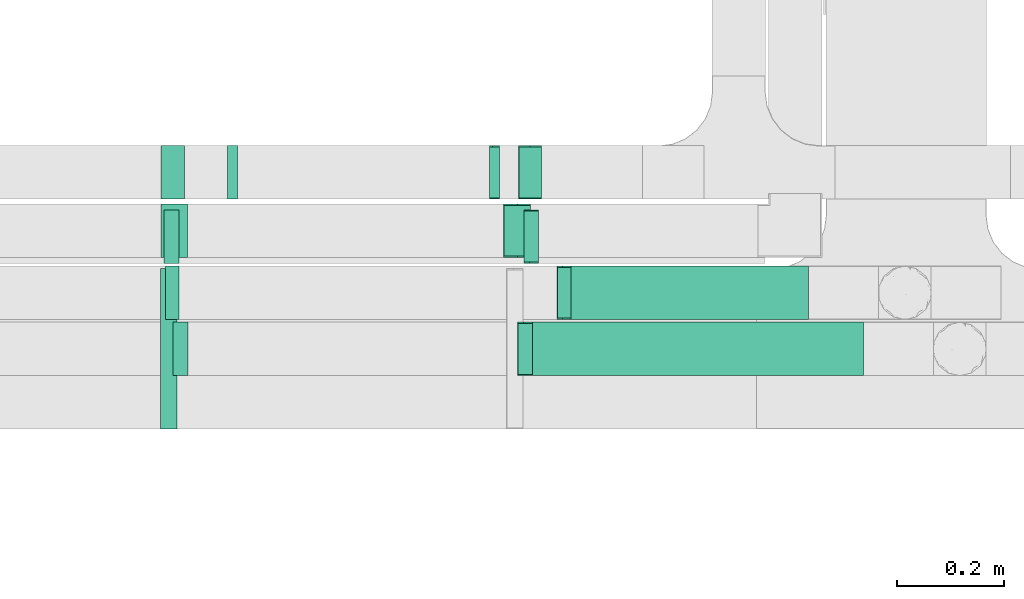
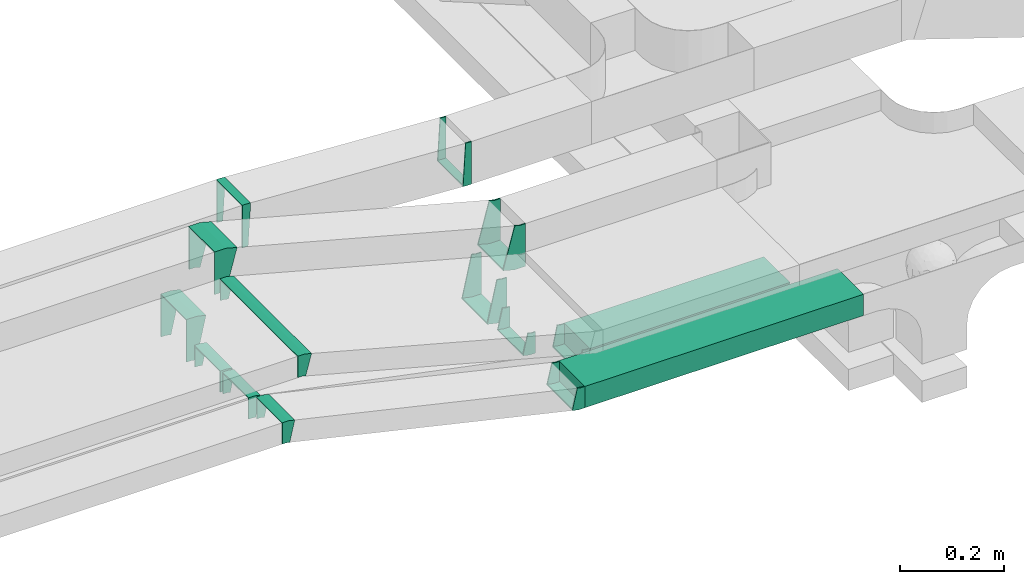
# One storey, part 13 of 18: 13 flow fittings, 2 flow segments.
"""IFC2X3 building model written with IfcOpenShell, lengths in millimetres."""

from ifc_helpers import new_model, entity, si_unit, converted_unit, derived_unit, direction, frame, frame_2d, origin, origin_2d_with_axis, place, context, subcontext, project, spatial, rectangle, extrude, faceted_brep, source, transform, mapped, material, type_object, type_shapes, element, save


model = new_model("IFC2X3")

# Units and contexts
model_context = context("Model", 3, precision=0.01, world=origin(), true_north=direction((6.12303176911189e-17, 1.0)))
body_context = subcontext(model_context, "Body", "Model", "MODEL_VIEW")
ifc_project = project(units=[si_unit("LENGTHUNIT", "METRE", prefix="MILLI"), si_unit("AREAUNIT", "SQUARE_METRE"), si_unit("VOLUMEUNIT", "CUBIC_METRE"), converted_unit("PLANEANGLEUNIT", "DEGREE", entity("IfcRatioMeasure", 0.0174532925199433), si_unit("PLANEANGLEUNIT", "RADIAN"), dimensions=[0, 0, 0, 0, 0, 0, 0]), si_unit("MASSUNIT", "GRAM", prefix="KILO"), derived_unit("MASSDENSITYUNIT", [(si_unit("MASSUNIT", "GRAM", prefix="KILO"), 1), (si_unit("LENGTHUNIT", "METRE"), -3)]), derived_unit("MOMENTOFINERTIAUNIT", [(si_unit("LENGTHUNIT", "METRE"), 4)]), si_unit("TIMEUNIT", "SECOND"), si_unit("FREQUENCYUNIT", "HERTZ"), si_unit("THERMODYNAMICTEMPERATUREUNIT", "DEGREE_CELSIUS"), derived_unit("THERMALTRANSMITTANCEUNIT", [(si_unit("MASSUNIT", "GRAM", prefix="KILO"), 1), (si_unit("THERMODYNAMICTEMPERATUREUNIT", "KELVIN"), -1), (si_unit("TIMEUNIT", "SECOND"), -3)]), derived_unit("VOLUMETRICFLOWRATEUNIT", [(si_unit("LENGTHUNIT", "METRE"), 3), (si_unit("TIMEUNIT", "SECOND"), -1)]), derived_unit("MASSFLOWRATEUNIT", [(si_unit("MASSUNIT", "GRAM", prefix="KILO"), 1), (si_unit("TIMEUNIT", "SECOND"), -1)]), derived_unit("ROTATIONALFREQUENCYUNIT", [(si_unit("TIMEUNIT", "SECOND"), -1)]), si_unit("ELECTRICCURRENTUNIT", "AMPERE"), si_unit("ELECTRICVOLTAGEUNIT", "VOLT"), si_unit("POWERUNIT", "WATT"), si_unit("FORCEUNIT", "NEWTON", prefix="KILO"), si_unit("ILLUMINANCEUNIT", "LUX"), si_unit("LUMINOUSFLUXUNIT", "LUMEN"), si_unit("LUMINOUSINTENSITYUNIT", "CANDELA"), derived_unit("USERDEFINED", [(si_unit("MASSUNIT", "GRAM", prefix="KILO"), -1), (si_unit("LENGTHUNIT", "METRE"), -2), (si_unit("TIMEUNIT", "SECOND"), 3), (si_unit("LUMINOUSFLUXUNIT", "LUMEN"), 1)]), derived_unit("LINEARVELOCITYUNIT", [(si_unit("LENGTHUNIT", "METRE"), 1), (si_unit("TIMEUNIT", "SECOND"), -1)]), si_unit("PRESSUREUNIT", "PASCAL"), derived_unit("USERDEFINED", [(si_unit("LENGTHUNIT", "METRE"), -2), (si_unit("MASSUNIT", "GRAM", prefix="KILO"), 1), (si_unit("TIMEUNIT", "SECOND"), -2)]), derived_unit("LINEARFORCEUNIT", [(si_unit("MASSUNIT", "GRAM", prefix="KILO"), 1), (si_unit("LENGTHUNIT", "METRE"), 1), (si_unit("TIMEUNIT", "SECOND"), -2), (si_unit("LENGTHUNIT", "METRE"), -1)]), derived_unit("PLANARFORCEUNIT", [(si_unit("MASSUNIT", "GRAM", prefix="KILO"), 1), (si_unit("LENGTHUNIT", "METRE"), 1), (si_unit("TIMEUNIT", "SECOND"), -2), (si_unit("LENGTHUNIT", "METRE"), -2)])], contexts=[model_context])

# Site, building, storey
site_placement = place(None, frame((0.0, -0.00077364408347762, 0.0)))
site = spatial("IfcSite", under=ifc_project, at=site_placement, CompositionType="ELEMENT")
building_placement = place(site_placement, origin())
building = spatial("IfcBuilding", under=site, at=building_placement, CompositionType="ELEMENT")
storey_placement = place(building_placement, frame((0.0, 0.0, 19800.0)))
storey = spatial("IfcBuildingStorey", under=building, at=storey_placement, CompositionType="ELEMENT", Elevation=19800.0)

# Flow segments
cable_carrier_segment_type = type_object("IfcCableCarrierSegmentType", PredefinedType="CABLETRAYSEGMENT")
flow_segment_1_placement = place(storey_placement, frame((63916.0659543254, 9720.00008284602, 2800.0)))
element("IfcFlowSegment", 1, at=flow_segment_1_placement, inside=storey, type_object=cable_carrier_segment_type, context=body_context, shape_type="SweptSolid", body=[
    extrude(rectangle(XDim=444.461560115162, YDim=99.9999999999989, at=origin_2d_with_axis()), frame((222.230780057581, 50.0, 0.0), z_axis=(0.0, 0.0, 1.0), x_axis=(-1.0, 0.0, 0.0)), (0.0, 0.0, 1.0), 49.9999999999973),
])
flow_segment_2_placement = place(storey_placement, frame((63844.3615033926, 9615.00008284603, 2800.0)))
element("IfcFlowSegment", 2, at=flow_segment_2_placement, inside=storey, type_object=cable_carrier_segment_type, context=body_context, shape_type="SweptSolid", body=[
    extrude(rectangle(XDim=618.676195552314, YDim=100.000000000001, at=frame_2d((4.34852154285181e-12, -5.43565192856477e-13), x_axis=(1.0, 0.0))), frame((309.338097776153, 50.0, 0.0), z_axis=(0.0, 0.0, 1.0), x_axis=(-1.0, 0.0, 0.0)), (0.0, 0.0, 1.0), 49.9999999999973),
])

# Flow fittings
ifc_material = material()
cable_carrier_fitting_type_1 = type_object("IfcCableCarrierFittingType", PredefinedType="NOTDEFINED", material=ifc_material)
shared_shape_1 = source(origin(), body_context, "Body", "Brep", [
    faceted_brep([(-12.240887367307, -25.0, 150.0), (-12.2408873673069, 25.0, 150.0), (-12.2408873673069, 25.0, 147.460000010164), (-12.240887367307, -22.46000001016, 147.460000010164), (-12.240887367307, -22.46000001016, -147.460000010156), (-12.2408873673069, 25.0, -147.460000010156), (-12.2408873673069, 25.0, -150.0), (-12.240887367307, -25.0, -150.0), (18.2942653723417, -20.9799708776128, 150.0), (18.2942653723417, -20.9799708776128, -150.0), (5.35331311721466, 27.3163204368403, -150.0), (5.35331311721466, 27.3163204368404, -147.460000010156), (17.6368650004108, -18.5265192886524, -147.460000010156), (17.6368650004108, -18.5265192886524, 147.460000010164), (5.35331311721466, 27.3163204368403, 147.460000010164), (5.35331311721466, 27.3163204368403, 150.0), (3.29131243968552, -25.0, 150.0), (-3.29131243968474, 25.0, 150.0), (-3.29131243968474, 25.0, 147.460000010164), (2.95691509715105, -22.46000001016, 147.460000010164), (2.95691509715105, -22.46000001016, -147.460000010156), (-3.29131243968474, 25.0, -147.460000010156), (-3.29131243968474, 25.0, -150.0), (3.29131243968546, -25.0, -150.0)], [[[0, 1, 2, 3, 4, 5, 6, 7]], [[8, 9, 10, 11, 12, 13, 14, 15]], [[1, 0, 16, 8, 15, 17]], [[2, 1, 17, 18]], [[3, 2, 18, 14, 13, 19]], [[4, 3, 19, 20]], [[5, 4, 20, 12, 11, 21]], [[6, 5, 21, 22]], [[7, 6, 22, 10, 9, 23]], [[0, 7, 23, 16]], [[18, 17, 15, 14]], [[20, 19, 13, 12]], [[22, 21, 11, 10]], [[16, 23, 9, 8]]]),
])
type_shapes(cable_carrier_fitting_type_1, [shared_shape_1])
flow_fitting_placement = place(storey_placement, frame((63161.1898333091, 9665.00005445351, 3200.0), z_axis=(0.0, -1.0, -1.62242998689715e-07), x_axis=(-0.965925826289063, -4.19915779954446e-08, 0.258819045102537)))
element("IfcFlowFitting", 3, at=flow_fitting_placement, inside=storey, type_object=cable_carrier_fitting_type_1, material=ifc_material, context=body_context, shape_type="MappedRepresentation", body=[
    mapped(shared_shape_1, transform((0.0, 0.0, 0.0), scale=1.0)),
])
cable_carrier_fitting_type_2 = type_object("IfcCableCarrierFittingType", PredefinedType="NOTDEFINED", material=ifc_material)
shared_shape_2 = source(origin(), body_context, "Body", "Brep", [
    faceted_brep([(-8.01131647543976, -50.0, 50.0), (-8.01131647543943, 50.0, 50.0), (-8.01131647543943, 50.0, 47.4600000101635), (-8.01131647543975, -47.46000001016, 47.4600000101635), (-8.01131647543975, -47.46000001016, -47.4600000101565), (-8.01131647543943, 50.0, -47.4600000101565), (-8.01131647543943, 50.0, -50.0), (-8.01131647543976, -50.0, -50.0), (10.8637122780125, -49.4586791899083, 50.0), (10.8637122780125, -49.4586791899083, -50.0), (5.13258520593124, 50.3769566446155, -50.0), (5.13258520593124, 50.3769566446155, -47.4600000101565), (10.7181416509639, -46.9228540498547, -47.4600000101565), (10.7181416509639, -46.9228540498547, 47.4600000101635), (5.13258520593124, 50.3769566446155, 47.4600000101635), (5.13258520593124, 50.3769566446155, 50.0), (1.43396022640025, -50.0, 50.0), (-1.43396022639952, 50.0, 50.0), (-1.43396022639952, 50.0, 47.4600000101635), (1.3611150471905, -47.46000001016, 47.4600000101635), (1.3611150471905, -47.46000001016, -47.4600000101565), (-1.43396022639952, 50.0, -47.4600000101565), (-1.43396022639952, 50.0, -50.0), (1.43396022640023, -50.0, -50.0)], [[[0, 1, 2, 3, 4, 5, 6, 7]], [[8, 9, 10, 11, 12, 13, 14, 15]], [[1, 0, 16, 8, 15, 17]], [[2, 1, 17, 18]], [[3, 2, 18, 14, 13, 19]], [[4, 3, 19, 20]], [[5, 4, 20, 12, 11, 21]], [[6, 5, 21, 22]], [[7, 6, 22, 10, 9, 23]], [[0, 7, 23, 16]], [[18, 17, 15, 14]], [[20, 19, 13, 12]], [[22, 21, 11, 10]], [[16, 23, 9, 8]]]),
])
type_shapes(cable_carrier_fitting_type_2, [shared_shape_2])
for number, where, z_axis, x_axis in (
    (4, (63281.772167546, 9995.00008284604, 3225.0), (0.0, 1.0, 0.0), (1.0, 0.0, 0.0)),
    (5, (63775.0597687343, 9995.00008284604, 3196.68251695043), (0.0, 1.0, 0.0), (-1.0, 0.0, 0.0)),
):
    element("IfcFlowFitting", number, at=place(storey_placement, frame(where, z_axis=z_axis, x_axis=x_axis)), inside=storey, type_object=cable_carrier_fitting_type_2, material=ifc_material, context=body_context, shape_type="MappedRepresentation", body=[
        mapped(shared_shape_2, transform((0.0, 0.0, 0.0), scale=1.0)),
    ])
cable_carrier_fitting_type_3 = type_object("IfcCableCarrierFittingType", PredefinedType="NOTDEFINED", material=ifc_material)
shared_shape_3 = source(origin(), body_context, "Body", "Brep", [
    faceted_brep([(-18.8235122466773, -50.0, 50.0), (-18.823512246677, 50.0, 50.0), (-18.823512246677, 50.0, 47.4600000101635), (-18.8235122466773, -47.4600000101599, 47.4600000101635), (-18.8235122466773, -47.4600000101599, -47.4600000101565), (-18.823512246677, 50.0, -47.4600000101565), (-18.823512246677, 50.0, -50.0), (-18.8235122466773, -50.0, -50.0), (31.1230688756617, -43.4244078492926, 50.0), (31.1230688756617, -43.4244078492926, -50.0), (5.24116436540786, 53.1681747796137, -50.0), (5.24116436540787, 53.1681747796137, -47.4600000101565), (30.4656685037309, -40.9709562603322, -47.4600000101565), (30.4656685037308, -40.9709562603322, 47.4600000101635), (5.24116436540786, 53.1681747796137, 47.4600000101635), (5.24116436540786, 53.1681747796137, 50.0), (6.5826248793706, -50.0, 50.0), (-6.58262487936983, 50.0, 50.0), (-6.58262487936983, 50.0, 47.4600000101635), (6.24822753683612, -47.46000001016, 47.4600000101635), (6.24822753683612, -47.46000001016, -47.4600000101565), (-6.58262487936983, 50.0, -47.4600000101565), (-6.58262487936983, 50.0, -50.0), (6.58262487937054, -50.0, -50.0)], [[[0, 1, 2, 3, 4, 5, 6, 7]], [[8, 9, 10, 11, 12, 13, 14, 15]], [[1, 0, 16, 8, 15, 17]], [[2, 1, 17, 18]], [[3, 2, 18, 14, 13, 19]], [[4, 3, 19, 20]], [[5, 4, 20, 12, 11, 21]], [[6, 5, 21, 22]], [[7, 6, 22, 10, 9, 23]], [[0, 7, 23, 16]], [[18, 17, 15, 14]], [[20, 19, 13, 12]], [[22, 21, 11, 10]], [[16, 23, 9, 8]]]),
])
type_shapes(cable_carrier_fitting_type_3, [shared_shape_3])
for number, where, z_axis, x_axis in (
    (6, (63168.285353888, 9886.00007211618, 3225.00003335971), (0.0, 1.0, 0.0), (1.0, 0.0, 0.0)),
    (7, (63821.3943697126, 9886.00007211623, 3050.0), (2.08688699966324e-08, -1.0, 7.78836831239711e-08), (0.965925826289059, 0.0, -0.258819045102554)),
):
    element("IfcFlowFitting", number, at=place(storey_placement, frame(where, z_axis=z_axis, x_axis=x_axis)), inside=storey, type_object=cable_carrier_fitting_type_3, material=ifc_material, context=body_context, shape_type="MappedRepresentation", body=[
        mapped(shared_shape_3, transform((0.0, 0.0, 0.0), scale=1.0)),
    ])
cable_carrier_fitting_type_4 = type_object("IfcCableCarrierFittingType", PredefinedType="NOTDEFINED", material=ifc_material)
shared_shape_4 = source(origin(), body_context, "Body", "Brep", [
    faceted_brep([(-11.2664584565903, -25.0, 50.0), (-11.2664584565901, 25.0, 50.0), (-11.2664584565901, 25.0, 47.4600000101635), (-11.2664584565903, -22.46000001016, 47.4600000101635), (-11.2664584565903, -22.46000001016, -47.4600000101565), (-11.2664584565901, 25.0, -47.4600000101565), (-11.2664584565901, 25.0, -50.0), (-11.2664584565903, -25.0, -50.0), (16.6014762148454, -21.8248499110999, 50.0), (16.6014762148454, -21.8248499110999, -50.0), (5.35392349765206, 26.8936533281618, -50.0), (5.35392349765206, 26.8936533281618, -47.4600000101565), (16.0301005390975, -19.349949956445, -47.4600000101565), (16.0301005390975, -19.349949956445, 47.4600000101635), (5.35392349765206, 26.8936533281618, 47.4600000101635), (5.35392349765206, 26.8936533281618, 50.0), (2.84839020754153, -25.0, 50.0), (-2.84839020754079, 25.0, 50.0), (-2.84839020754079, 25.0, 47.4600000101635), (2.55899376361288, -22.46000001016, 47.4600000101635), (2.55899376361288, -22.46000001016, -47.4600000101565), (-2.84839020754079, 25.0, -47.4600000101565), (-2.84839020754079, 25.0, -50.0), (2.84839020754148, -25.0, -50.0)], [[[0, 1, 2, 3, 4, 5, 6, 7]], [[8, 9, 10, 11, 12, 13, 14, 15]], [[1, 0, 16, 8, 15, 17]], [[2, 1, 17, 18]], [[3, 2, 18, 14, 13, 19]], [[4, 3, 19, 20]], [[5, 4, 20, 12, 11, 21]], [[6, 5, 21, 22]], [[7, 6, 22, 10, 9, 23]], [[0, 7, 23, 16]], [[18, 17, 15, 14]], [[20, 19, 13, 12]], [[22, 21, 11, 10]], [[16, 23, 9, 8]]]),
])
type_shapes(cable_carrier_fitting_type_4, [shared_shape_4])
for number, where, z_axis, x_axis in (
    (8, (63833.095044936, 9665.00008284603, 2825.0), (0.0, 1.0, 0.0), (-1.0, 0.0, 0.0)),
    (9, (63183.3736637934, 9665.00008284604, 2975.0), (0.0, -1.0, 0.0), (-0.974370064785237, 0.0, 0.22495105434386)),
):
    element("IfcFlowFitting", number, at=place(storey_placement, frame(where, z_axis=z_axis, x_axis=x_axis)), inside=storey, type_object=cable_carrier_fitting_type_4, material=ifc_material, context=body_context, shape_type="MappedRepresentation", body=[
        mapped(shared_shape_4, transform((0.0, 0.0, 0.0), scale=1.0)),
    ])
cable_carrier_fitting_type_5 = type_object("IfcCableCarrierFittingType", PredefinedType="NOTDEFINED", material=ifc_material)
shared_shape_5 = source(origin(), body_context, "Body", "Brep", [
    faceted_brep([(-10.5384398848335, -25.0, 50.0), (-10.5384398848333, 25.0, 50.0), (-10.5384398848333, 25.0, 47.4600000101635), (-10.5384398848335, -22.46000001016, 47.4600000101635), (-10.5384398848335, -22.46000001016, -47.4600000101565), (-10.5384398848333, 25.0, -47.4600000101565), (-10.5384398848333, 25.0, -50.0), (-10.5384398848335, -25.0, -50.0), (15.311262278676, -22.3969632459377, 50.0), (15.311262278676, -22.3969632459377, -50.0), (5.34245794520471, 26.599189053615, -50.0), (5.34245794520471, 26.599189053615, -47.4600000101565), (14.8048470205613, -19.9079587190764, -47.4600000101565), (14.8048470205613, -19.9079587190764, 47.4600000101635), (5.34245794520471, 26.599189053615, 47.4600000101635), (5.34245794520472, 26.599189053615, 50.0), (2.51747267492481, -25.0, 50.0), (-2.51747267492408, 25.0, 50.0), (-2.51747267492408, 25.0, 47.4600000101635), (2.26169745217554, -22.46000001016, 47.4600000101635), (2.26169745217554, -22.46000001016, -47.4600000101565), (-2.51747267492408, 25.0, -47.4600000101565), (-2.51747267492408, 25.0, -50.0), (2.51747267492476, -25.0, -50.0)], [[[0, 1, 2, 3, 4, 5, 6, 7]], [[8, 9, 10, 11, 12, 13, 14, 15]], [[1, 0, 16, 8, 15, 17]], [[2, 1, 17, 18]], [[3, 2, 18, 14, 13, 19]], [[4, 3, 19, 20]], [[5, 4, 20, 12, 11, 21]], [[6, 5, 21, 22]], [[7, 6, 22, 10, 9, 23]], [[0, 7, 23, 16]], [[18, 17, 15, 14]], [[20, 19, 13, 12]], [[22, 21, 11, 10]], [[16, 23, 9, 8]]]),
])
type_shapes(cable_carrier_fitting_type_5, [shared_shape_5])
for number, where, z_axis, x_axis in (
    (10, (63905.5275144406, 9770.00008284603, 2825.0), (0.0, 1.0, 0.0), (-1.0, 0.0, 0.0)),
    (11, (63168.285353888, 9770.00008284604, 2975.0), (0.0, -1.0, 0.0), (-0.979923045991058, 0.0, 0.199376086669409)),
):
    element("IfcFlowFitting", number, at=place(storey_placement, frame(where, z_axis=z_axis, x_axis=x_axis)), inside=storey, type_object=cable_carrier_fitting_type_5, material=ifc_material, context=body_context, shape_type="MappedRepresentation", body=[
        mapped(shared_shape_5, transform((0.0, 0.0, 0.0), scale=1.0)),
    ])
cable_carrier_fitting_type_6 = type_object("IfcCableCarrierFittingType", PredefinedType="NOTDEFINED", material=ifc_material)
shared_shape_6 = source(origin(), body_context, "Body", "Brep", [
    faceted_brep([(-11.120571380929, -25.0, 50.0), (-11.1205713809288, 25.0, 50.0), (-11.1205713809288, 25.0, 47.4600000101635), (-11.120571380929, -22.46000001016, 47.4600000101635), (-11.120571380929, -22.46000001016, -47.4600000101565), (-11.1205713809288, 25.0, -47.4600000101565), (-11.1205713809288, 25.0, -50.0), (-11.120571380929, -25.0, -50.0), (16.3446003649651, -21.9435901061782, 50.0), (16.3446003649651, -21.9435901061782, -50.0), (5.35241523546609, 26.8331652807766, -50.0), (5.35241523546609, 26.8331652807766, -47.4600000101565), (15.7861973626201, -19.4657309424323, -47.4600000101565), (15.7861973626201, -19.4657309424323, 47.4600000101635), (5.35241523546609, 26.8331652807766, 47.4600000101635), (5.35241523546608, 26.8331652807766, 50.0), (2.78207790042274, -25.0, 50.0), (-2.782077900422, 25.0, 50.0), (-2.782077900422, 25.0, 47.4600000101635), (2.49941878687041, -22.46000001016, 47.4600000101635), (2.49941878687041, -22.46000001016, -47.4600000101565), (-2.782077900422, 25.0, -47.4600000101565), (-2.782077900422, 25.0, -50.0), (2.78207790042269, -25.0, -50.0)], [[[0, 1, 2, 3, 4, 5, 6, 7]], [[8, 9, 10, 11, 12, 13, 14, 15]], [[1, 0, 16, 8, 15, 17]], [[2, 1, 17, 18]], [[3, 2, 18, 14, 13, 19]], [[4, 3, 19, 20]], [[5, 4, 20, 12, 11, 21]], [[6, 5, 21, 22]], [[7, 6, 22, 10, 9, 23]], [[0, 7, 23, 16]], [[18, 17, 15, 14]], [[20, 19, 13, 12]], [[22, 21, 11, 10]], [[16, 23, 9, 8]]]),
])
type_shapes(cable_carrier_fitting_type_6, [shared_shape_6])
for number, where, z_axis, x_axis in (
    (12, (63844.466171003, 9875.00008284608, 2822.26886638619), (0.0, 1.0, 0.0), (-1.0, 0.0, 0.0)),
    (13, (63166.7365788893, 9875.00008284607, 2975.0), (0.0, -1.0, 0.0), (-0.975535107739096, 0.0, 0.219843702589976)),
):
    element("IfcFlowFitting", number, at=place(storey_placement, frame(where, z_axis=z_axis, x_axis=x_axis)), inside=storey, type_object=cable_carrier_fitting_type_6, material=ifc_material, context=body_context, shape_type="MappedRepresentation", body=[
        mapped(shared_shape_6, transform((0.0, 0.0, 0.0), scale=1.0)),
    ])
cable_carrier_fitting_type_7 = type_object("IfcCableCarrierFittingType", PredefinedType="NOTDEFINED", material=ifc_material)
shared_shape_7 = source(origin(), body_context, "Body", "Brep", [
    faceted_brep([(-16.4659062870849, -50.0, 50.0), (-16.4659062870846, 50.0, 50.0), (-16.4659062870846, 50.0, 47.4600000101635), (-16.4659062870849, -47.4600000101599, 47.4600000101635), (-16.4659062870849, -47.4600000101599, -47.4600000101565), (-16.4659062870846, 50.0, -47.4600000101565), (-16.4659062870846, 50.0, -50.0), (-16.4659062870849, -50.0, -50.0), (26.86907147442, -45.267859105083, 50.0), (26.86907147442, -45.267859105083, -50.0), (5.28660886523991, 52.3753552404277, -50.0), (5.2866088652399, 52.3753552404277, -47.4600000101565), (26.3208769263396, -42.7877214706276, -47.4600000101565), (26.3208769263396, -42.7877214706276, 47.4600000101635), (5.28660886523991, 52.3753552404277, 47.4600000101635), (5.28660886523991, 52.3753552404277, 50.0), (5.45995537480279, -50.0, 50.0), (-5.45995537480202, 50.0, 50.0), (-5.45995537480202, 50.0, 47.4600000101635), (5.18258964287224, -47.46000001016, 47.4600000101635), (5.18258964287224, -47.46000001016, -47.4600000101565), (-5.45995537480202, 50.0, -47.4600000101565), (-5.45995537480202, 50.0, -50.0), (5.45995537480274, -50.0, -50.0)], [[[0, 1, 2, 3, 4, 5, 6, 7]], [[8, 9, 10, 11, 12, 13, 14, 15]], [[1, 0, 16, 8, 15, 17]], [[2, 1, 17, 18]], [[3, 2, 18, 14, 13, 19]], [[4, 3, 19, 20]], [[5, 4, 20, 12, 11, 21]], [[6, 5, 21, 22]], [[7, 6, 22, 10, 9, 23]], [[0, 7, 23, 16]], [[18, 17, 15, 14]], [[20, 19, 13, 12]], [[22, 21, 11, 10]], [[16, 23, 9, 8]]]),
])
type_shapes(cable_carrier_fitting_type_7, [shared_shape_7])
for number, where, z_axis, x_axis in (
    (14, (63845.1221386505, 9995.00008284604, 2850.0), (0.0, 1.0, 0.0), (-1.0, 0.0, 0.0)),
    (15, (63166.4932714518, 9995.00008284603, 3000.0), (0.0, 1.0, 0.0), (1.0, 0.0, 0.0)),
):
    element("IfcFlowFitting", number, at=place(storey_placement, frame(where, z_axis=z_axis, x_axis=x_axis)), inside=storey, type_object=cable_carrier_fitting_type_7, material=ifc_material, context=body_context, shape_type="MappedRepresentation", body=[
        mapped(shared_shape_7, transform((0.0, 0.0, 0.0), scale=1.0)),
    ])

save(model, "model.ifc")
